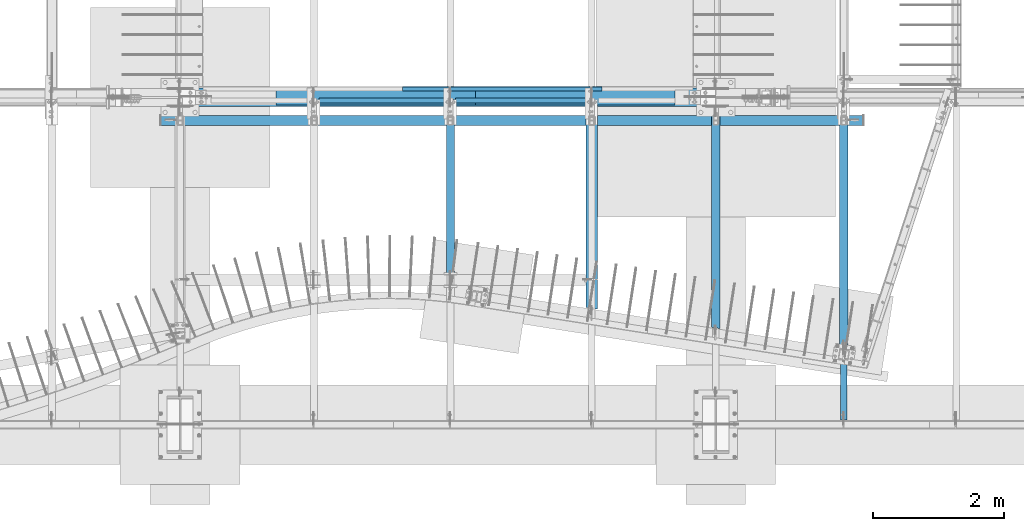
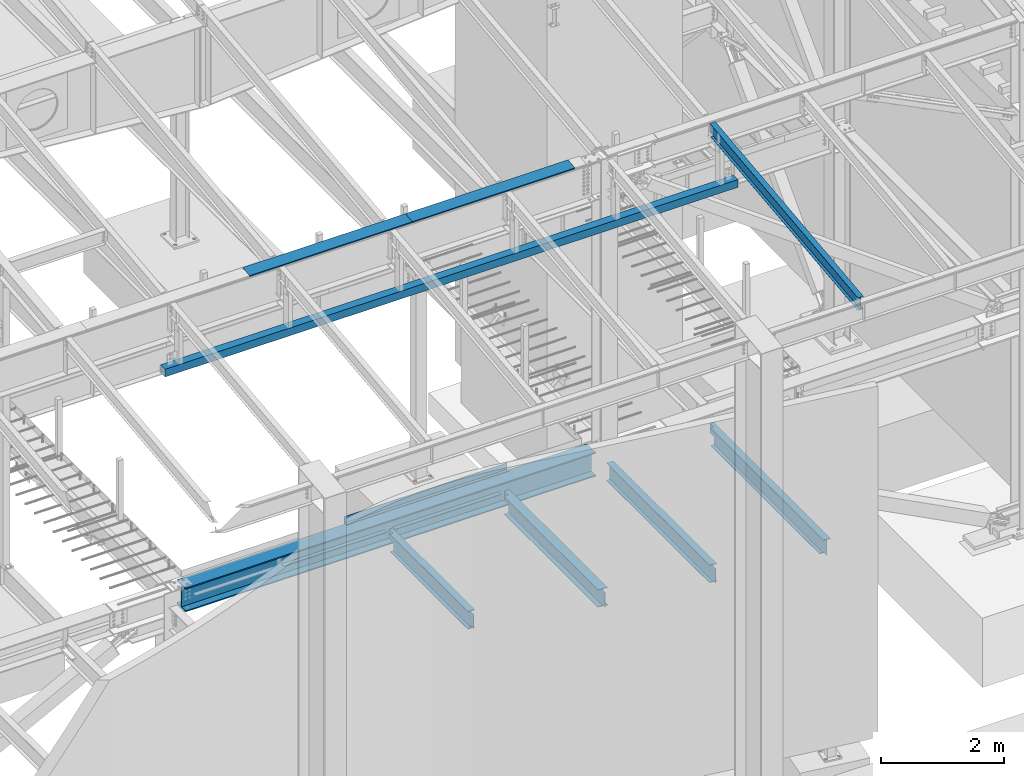
# One storey, part 713 of 1179: 12 beams, 8 elements without a shape of their own.
"""IFC2X3 building model written with IfcOpenShell, lengths in millimetres."""

from ifc_helpers import new_model, si_unit, frame, origin_with_axes, place, context, subcontext, project, spatial, faceted_brep, material, type_object, element, aggregate, save


model = new_model("IFC2X3")

# Units and contexts
model_context = context("Model", 3, precision=1e-05, world=origin_with_axes())
body_context = subcontext(model_context, "Body", "Model", "MODEL_VIEW")
ifc_project = project(units=[si_unit("LENGTHUNIT", "METRE", prefix="MILLI"), si_unit("AREAUNIT", "SQUARE_METRE"), si_unit("VOLUMEUNIT", "CUBIC_METRE"), si_unit("MASSUNIT", "GRAM", prefix="KILO"), si_unit("TIMEUNIT", "SECOND"), si_unit("PLANEANGLEUNIT", "RADIAN"), si_unit("SOLIDANGLEUNIT", "STERADIAN"), si_unit("THERMODYNAMICTEMPERATUREUNIT", "DEGREE_CELSIUS"), si_unit("LUMINOUSINTENSITYUNIT", "LUMEN")], contexts=[model_context])

# Site, building, storey
site_placement = place(None, origin_with_axes())
site = spatial("IfcSite", under=ifc_project, at=site_placement, CompositionType="ELEMENT")
building_placement = place(site_placement, origin_with_axes())
building = spatial("IfcBuilding", under=site, at=building_placement, Name="Undefined", CompositionType="ELEMENT")
storey_placement = place(building_placement, origin_with_axes())
storey = spatial("IfcBuildingStorey", under=building, at=storey_placement, Name="Undefined", CompositionType="ELEMENT", Elevation=0.0)

# Assembly, beam
assembly_1_placement = place(storey_placement, origin_with_axes())
assembly_1 = element("IfcElementAssembly", 1, at=assembly_1_placement, inside=storey, Name="BEAM", AssemblyPlace="NOTDEFINED", PredefinedType="RIGID_FRAME")
ifc_material_1 = material(Name="STEEL/A992")
beam_type_1 = type_object("IfcBeamType", Name="W10X12", PredefinedType="NOTDEFINED")
beam_1_placement = place(assembly_1_placement, frame((18415.0, 452.231593993459, 9171.78056384809), z_axis=(-3.89779463887408e-08, -0.112282221021699, 0.993676357192035), x_axis=(0.0, 0.993676357192036, 0.112282221021699)))
beam_1 = element("IfcBeam", 2, at=beam_1_placement, type_object=beam_type_1, material=ifc_material_1, Name="BEAM", ObjectType="W10X12", context=body_context, shape_type="Brep", body=[
    faceted_brep([(4858.49015079339, 2.38124999999854, -120.649999999368), (4858.49015079341, 2.38119320135957, -125.412499999364), (4858.49013956012, 50.7999999999993, -125.412499999362), (4858.49013956012, 50.7999999999993, -120.649999999367), (4983.08589598448, 2.38124999999854, -120.649999999354), (4982.54774885665, 2.38122198294514, -125.412499999351), (48.8806597554974, -2.38124999999854, -120.649999999914), (48.8806597554974, -50.7999999999993, -120.649999999914), (4858.49016309746, -50.7999999999993, -120.649999999367), (4858.49015186424, -2.38124999999854, -120.649999999367), (76.1467808989316, 2.38124999999854, 120.649999999929), (76.1467808989316, 50.7999999999993, 120.649999999929), (4914.49585701086, 50.7999999999993, 120.650000000478), (4914.49585701086, 2.38124999999854, 120.650000000478), (48.3425126276663, -50.7999999999993, -125.412499999911), (76.1467808989316, -2.38124999999854, 120.649999999929), (76.1467808989316, -50.7999999999993, 120.649999999929), (76.6849280267622, -50.7999999999993, 125.412499999924), (76.6849280267622, 50.7999999999993, 125.412499999924), (48.8806597554974, 2.38124999999854, -120.649999999914), (48.8806597554974, 50.7999999999993, -120.649999999914), (48.3425126276663, 50.7999999999993, -125.412499999911), (4858.49016309746, -50.7999999999993, -125.412499999364), (4858.49015186426, -2.38130674932472, -125.412499999364), (4983.08589598448, -2.38124999999854, -120.649999999354), (4982.54774885665, -2.3812779679356, -125.412499999351), (4916.56631885514, -2.38124999999854, 69.1498492601459), (4912.78131142652, -2.38124999999854, 72.3480766489138), (4910.50832916744, -2.38124999999854, 76.7513131080195), (4910.0934130222, -2.38124999999854, 81.6892058020039), (4914.49585701086, -2.38124999999854, 120.650000000478), (4983.1719256045, -2.38124999999854, -119.888654181221), (5003.31510185873, -2.38124999999854, 58.3746347029464), (4921.28711838346, -2.38124999999854, 67.6435320696546), (4914.49585701086, -50.7999999999993, 120.650000000478), (4915.03400413869, -50.7999999999993, 125.412500000475), (4915.03400413869, 50.7999999999993, 125.412500000475), (4910.0934130222, 2.38124999999854, 81.6892058020039), (4910.50832916744, 2.38124999999854, 76.7513131080195), (4912.78131142652, 2.38124999999854, 72.3480766489138), (4916.56631885514, 2.38124999999854, 69.1498492601459), (4921.28711838346, 2.38124999999854, 67.6435320696546), (5003.31510185873, 2.38124999999854, 58.3746347029464), (4983.17191277243, 2.38124999999854, -119.888767742599)], [[[0, 1, 2, 3]], [[4, 5, 1, 0]], [[6, 7, 8, 9]], [[10, 11, 12, 13]], [[14, 7, 6, 15, 16, 17, 18, 11, 10, 19, 20, 21]], [[7, 14, 22, 8]], [[8, 22, 23, 9]], [[24, 9, 23, 25]], [[26, 27, 28, 29, 30, 15, 6, 9, 24, 31, 32, 33]], [[16, 15, 30, 34]], [[17, 16, 34, 35]], [[18, 17, 35, 36]], [[11, 18, 36, 12]], [[35, 34, 30, 29, 37, 13, 12, 36]], [[28, 38, 37, 29]], [[27, 39, 38, 28]], [[26, 40, 39, 27]], [[33, 41, 40, 26]], [[32, 42, 41, 33]], [[43, 4, 0, 19, 10, 13, 37, 38, 39, 40, 41, 42]], [[20, 19, 0, 3]], [[21, 20, 3, 2]], [[25, 23, 22, 14, 21, 2, 1, 5]], [[43, 42, 32, 31, 24, 25, 5, 4]]]),
])
aggregate(assembly_1, [beam_1])

assembly_2_placement = place(storey_placement, origin_with_axes())
assembly_2 = element("IfcElementAssembly", 3, at=assembly_2_placement, inside=storey, Name="BEAM", AssemblyPlace="NOTDEFINED", PredefinedType="RIGID_FRAME")
ifc_material_2 = material(Name="STEEL/A36")
beam_type_2 = type_object("IfcBeamType", PredefinedType="NOTDEFINED")
beam_2_placement = place(assembly_2_placement, frame((13198.475, 5597.525, 4235.45000610352), z_axis=(1.0, 0.0, 0.0), x_axis=(0.0, 0.0, -1.0)))
beam_2 = element("IfcBeam", 4, at=beam_2_placement, type_object=beam_type_2, material=ifc_material_2, Name="BENT_PLATE", context=body_context, shape_type="Brep", body=[
    faceted_brep([(0.0, -3.17499999999927, -1524.0), (6.00266503170133e-10, -3.17499999922438, 1524.00000000052), (6.00266503170133e-10, 3.17500000077416, 1524.00000000052), (0.0, 3.17499999999927, -1524.0), (133.350006103513, 3.17500000000291, 1524.0), (133.350006103513, 3.17500000000291, -1524.0), (127.000006103513, -3.17500000000291, -1524.0), (127.000006103513, -3.17500000000291, 1524.0), (133.350006103516, -60.3250000000016, 1524.0), (133.350006103516, -60.3250000000016, -1524.0), (127.000006103515, -60.3250000000016, 1524.0), (127.000006103515, -60.3250000000016, -1524.0)], [[[0, 1, 2, 3]], [[3, 2, 4, 5]], [[1, 0, 6, 7]], [[5, 4, 8, 9]], [[4, 2, 1, 7, 10, 8]], [[7, 6, 11, 10]], [[6, 0, 3, 5, 9, 11]], [[10, 11, 9, 8]]]),
])

# Assembly, beams
assembly_3_placement = place(storey_placement, origin_with_axes())
assembly_3 = element("IfcElementAssembly", 5, at=assembly_3_placement, inside=storey, Name="BEAM", AssemblyPlace="NOTDEFINED", PredefinedType="RIGID_FRAME")
beam_type_3 = type_object("IfcBeamType", PredefinedType="NOTDEFINED")
beam_3_placement = place(assembly_3_placement, frame((14316.0749993252, 5543.55933465636, 9826.91628422077), z_axis=(-1.0, 0.0, 0.0), x_axis=(0.0, 0.0, 1.0)))
beam_3 = element("IfcBeam", 6, at=beam_3_placement, type_object=beam_type_3, material=ifc_material_2, Name="BENT_PLATE", context=body_context, shape_type="Brep", body=[
    faceted_brep([(-2.91038304567337e-11, -4.76250000000073, -1524.0), (-2.91038304567337e-11, -4.76250000000073, 1524.0), (2.91038304567337e-11, 4.76250000000073, 1524.0), (2.91038304567337e-11, 4.76250000000073, -1524.0), (46.9151566473611, 4.76249999974698, 1524.0), (46.9151566473611, 4.76249999974698, -1524.0), (36.2535598523627, -4.76250000019536, -1524.0), (36.2535598523627, -4.76250000019536, 1524.0), (21.449529282756, -220.662499999238, 1524.0), (21.449529282756, -220.662499999238, -1524.0), (12.939957335464, -211.13749999934, -1524.0), (12.939957335464, -211.13749999934, 1524.0), (1.17463059723377e-07, -220.662499999494, 1524.0), (1.17463059723377e-07, -220.662499999494, -1524.0), (1.17350282380357e-07, -211.137499999494, 1524.0), (1.17350282380357e-07, -211.137499999494, -1524.0)], [[[0, 1, 2, 3]], [[3, 2, 4, 5]], [[1, 0, 6, 7]], [[5, 4, 8, 9]], [[7, 6, 10, 11]], [[9, 8, 12, 13]], [[8, 4, 2, 1, 7, 11, 14, 12]], [[11, 10, 15, 14]], [[10, 6, 0, 3, 5, 9, 13, 15]], [[14, 15, 13, 12]]]),
])
beam_4_placement = place(assembly_3_placement, frame((11268.0749993267, 5543.55933465737, 9826.91628422066), z_axis=(-1.0, 0.0, 0.0), x_axis=(0.0, 0.0, 1.0)))
beam_4 = element("IfcBeam", 7, at=beam_4_placement, type_object=beam_type_3, material=ifc_material_2, Name="BENT_PLATE", context=body_context, shape_type="Brep", body=[
    faceted_brep([(-2.91038304567337e-11, -4.76250000000073, -1524.0), (-2.91038304567337e-11, -4.76250000000073, 1524.0), (2.91038304567337e-11, 4.76250000000073, 1524.0), (2.91038304567337e-11, 4.76250000000073, -1524.0), (46.9151566473611, 4.76249999974698, 1524.0), (46.9151566473611, 4.76249999974698, -1524.0), (36.2535598523627, -4.76250000019536, -1524.0), (36.2535598523627, -4.76250000019536, 1524.0), (21.449529282756, -220.662499999238, 1524.0), (21.449529282756, -220.662499999238, -1524.0), (12.939957335464, -211.13749999934, -1524.0), (12.939957335464, -211.13749999934, 1524.0), (1.17463059723377e-07, -220.662499999494, 1524.0), (1.17463059723377e-07, -220.662499999494, -1524.0), (1.17350282380357e-07, -211.137499999494, 1524.0), (1.17350282380357e-07, -211.137499999494, -1524.0)], [[[0, 1, 2, 3]], [[3, 2, 4, 5]], [[1, 0, 6, 7]], [[5, 4, 8, 9]], [[7, 6, 10, 11]], [[9, 8, 12, 13]], [[8, 4, 2, 1, 7, 11, 14, 12]], [[11, 10, 15, 14]], [[10, 6, 0, 3, 5, 9, 13, 15]], [[14, 15, 13, 12]]]),
])
aggregate(assembly_3, [beam_3, beam_4])

# Beam
beam_type_4 = type_object("IfcBeamType", PredefinedType="NOTDEFINED")
beam_5_placement = place(assembly_2_placement, frame((12484.1, 5390.35625, 3844.13073387436), z_axis=(0.0, 1.0, 0.0), x_axis=(1.0, 0.0, 0.0)))
beam_5 = element("IfcBeam", 8, at=beam_5_placement, type_object=beam_type_4, material=ifc_material_2, Name="PLATE", context=body_context, shape_type="Brep", body=[
    faceted_brep([(0.0, 3.96900000000005, -38.1000000000004), (0.0, 3.96900000000005, 38.1000000000004), (1984.375, 3.96900000000005, 38.1000000000004), (1984.375, 3.96900000000005, -38.1000000000004), (-3.63797880709171e-12, -3.96900000000005, 38.1000000000004), (1984.375, -3.96900000000005, 38.1000000000004), (-3.63797880709171e-12, -3.96900000000005, -38.1000000000004), (1984.375, -3.96900000000005, -38.1000000000004)], [[[0, 1, 2, 3]], [[1, 4, 5, 2]], [[4, 6, 7, 5]], [[6, 0, 3, 7]], [[5, 7, 3, 2]], [[6, 4, 1, 0]]]),
])

beam_6_placement = place(assembly_2_placement, frame((10401.3, 5390.35625, 3844.13073387436), z_axis=(0.0, 1.0, 0.0), x_axis=(1.0, 0.0, 0.0)))
beam_6 = element("IfcBeam", 9, at=beam_6_placement, type_object=beam_type_4, material=ifc_material_2, Name="PLATE", context=body_context, shape_type="Brep", body=[
    faceted_brep([(0.0, 3.96900000000005, -38.1000000000004), (0.0, 3.96900000000005, 38.1000000000004), (1930.4, 3.96900000000005, 38.1000000000004), (1930.4, 3.96900000000005, -38.1000000000004), (-3.63797880709171e-12, -3.96900000000005, 38.1000000000004), (1930.4, -3.96900000000005, 38.1000000000004), (-3.63797880709171e-12, -3.96900000000005, -38.1000000000004), (1930.4, -3.96900000000005, -38.1000000000004)], [[[0, 1, 2, 3]], [[1, 4, 5, 2]], [[4, 6, 7, 5]], [[6, 0, 3, 7]], [[5, 7, 3, 2]], [[6, 4, 1, 0]]]),
])

# Assembly, beam
assembly_4_placement = place(storey_placement, origin_with_axes())
assembly_4 = element("IfcElementAssembly", 10, at=assembly_4_placement, inside=storey, Name="BEAM", AssemblyPlace="NOTDEFINED", PredefinedType="RIGID_FRAME")
ifc_material_3 = material()
beam_type_5 = type_object("IfcBeamType", Name="HSS6X6X1/4", PredefinedType="NOTDEFINED")
beam_7_placement = place(assembly_4_placement, frame((7975.6, 5086.35, 8724.9), z_axis=(0.0, 0.0, 1.0), x_axis=(1.0, 0.0, 0.0)))
beam_7 = element("IfcBeam", 11, at=beam_7_placement, type_object=beam_type_5, material=ifc_material_3, Name="BEAM", ObjectType="HSS6X6X1/4", context=body_context, shape_type="Brep", body=[
    faceted_brep([(6.34999999999945, 69.8500000000004, -69.8500000000004), (6.34999999999945, -69.8500000000004, -69.8500000000004), (10737.85, -69.8500000000004, -69.8500000000004), (10737.85, 69.8500000000004, -69.8500000000004), (6.34999999999945, -69.8500000000004, 69.8500000000004), (10737.85, -69.8500000000004, 69.8500000000004), (6.34999999999945, 69.8500000000004, 69.8500000000004), (10737.85, 69.8500000000004, 69.8500000000004), (6.34999999999945, 76.1999999999998, -76.2000000000007), (6.34999999999945, 76.1999999999998, 76.2000000000007), (10737.85, 76.1999999999998, 76.2000000000007), (10737.85, 76.1999999999998, -76.2000000000007), (6.34999999999945, -76.1999999999998, 76.2000000000007), (10737.85, -76.1999999999998, 76.2000000000007), (6.34999999999945, -76.1999999999998, -76.2000000000007), (10737.85, -76.1999999999998, -76.2000000000007)], [[[0, 1, 2, 3]], [[1, 4, 5, 2]], [[4, 6, 7, 5]], [[6, 0, 3, 7]], [[8, 9, 10, 11]], [[9, 12, 13, 10]], [[12, 14, 15, 13]], [[14, 8, 11, 15]], [[13, 15, 11, 10], [5, 7, 3, 2]], [[14, 12, 9, 8], [6, 4, 1, 0]]]),
])
aggregate(assembly_4, [beam_7])

assembly_5_placement = place(storey_placement, origin_with_axes())
assembly_5 = element("IfcElementAssembly", 12, at=assembly_5_placement, inside=storey, Name="BEAM", AssemblyPlace="NOTDEFINED", PredefinedType="RIGID_FRAME")
beam_type_6 = type_object("IfcBeamType", Name="W14X26", PredefinedType="NOTDEFINED")
beam_8_placement = place(assembly_5_placement, frame((12407.9, 2647.95, 3671.8875), z_axis=(0.0, 0.0, 1.0), x_axis=(0.0, 1.0, 0.0)))
beam_8 = element("IfcBeam", 13, at=beam_8_placement, type_object=beam_type_6, material=ifc_material_1, Name="BEAM", ObjectType="W14X26", context=body_context, shape_type="Brep", body=[
    faceted_brep([(2620.9625003817, 28.5749995954666, 176.2125), (2620.9625003817, 28.5749995954666, 165.1), (2620.96250020706, 63.5, 165.1), (2620.96250020706, 63.5, 176.2125), (2622.89596027548, 18.8548405690453, 176.2125), (2622.89596027548, 18.8548405690453, 165.1), (2628.40198811764, 10.6144876602702, 176.2125), (2628.40198811764, 10.6144876602702, 165.1), (2636.64234108148, 5.10845990051894, 176.2125), (2636.64234108148, 5.10845990051894, 165.1), (2646.36250012724, 3.17500010394724, 176.2125), (2646.36250012724, 3.17499999999927, 165.1), (2755.10639088957, 3.17500064769047, 176.2125), (2755.10638849583, 3.17499999999927, 165.1), (95.2499884076783, 3.17499999999927, 165.1), (95.2499884076783, 63.5, 165.1), (101.665597189517, 63.5, 176.2125), (101.665597189517, -63.5, 176.2125), (2755.10638849583, -63.5, 176.2125), (2755.10638849583, -63.5, 165.1), (95.2499884076783, -63.5, 165.1), (2755.10638849583, -3.17499999999927, 165.1), (95.2499884076783, -3.17499999999927, 165.1), (95.020787505794, 3.17499999999927, 164.703000259399), (95.020787505794, -3.17499999999927, 164.703000259399), (117.474996948922, 3.17499999999927, 164.703000259399), (117.474996948922, -3.17499999999927, 164.703000259399), (133.804034531066, 3.17499999999927, 158.045004848507), (133.804034531066, -3.17499999999927, 158.045004848507), (137.888773595438, 3.17499999999927, 154.857742002601), (137.888773595438, -3.17499999999927, 154.857742002601), (139.700870417409, 3.17499999999927, 150.003873155928), (139.700870417409, -3.17499999999927, 150.003873155928), (138.704164947125, 3.17499999999927, 144.919552564306), (138.704164947125, -3.17499999999927, 144.919552564306), (135.193560662237, 3.17499999999927, 141.10912014425), (135.193560662237, -3.17499999999927, 141.10912014425), (130.207769040842, 3.17499999999927, 139.7), (130.207769040842, -3.17499999999927, 139.7), (15.8750000000027, 3.17499999999927, 139.7), (15.8750000000027, -3.17499999999927, 139.7), (15.8750000000027, 3.17499999999927, 138.112500000001), (15.8750000000027, 3.17499999999927, -92.4874999999997), (15.8750000000027, 3.17499999999927, -139.7), (15.8750000000027, -3.17499999999927, -139.7), (137.081772947067, 3.17499999999927, -139.7), (137.081772947067, -3.17499999999927, -139.7), (142.067564568461, 3.17499999999927, -141.10912014425), (142.067564568461, -3.17499999999927, -141.10912014425), (145.578168853349, 3.17499999999927, -144.919552564306), (145.578168853349, -3.17499999999927, -144.919552564306), (146.574874323633, 3.17499999999927, -150.003873155929), (146.574874323633, -3.17499999999927, -150.003873155929), (144.762777501662, 3.17499999999927, -154.857742002601), (144.762777501662, -3.17499999999927, -154.857742002601), (140.678038437291, 3.17499999999927, -158.045004848507), (140.678038437291, -3.17499999999927, -158.045004848507), (124.349000855147, 3.17499999999927, -164.703000259399), (124.349000855147, -3.17499999999927, -164.703000259399), (101.894810700874, 3.17499999999927, -164.703000259399), (101.894810700874, -3.17499999999927, -164.703000259399), (101.665622677133, -3.17499999999927, -165.1), (2620.96249811497, -3.17499999999927, -165.1), (2620.96249811497, -3.17499999999927, -36.5124996185305), (2622.89595796015, -3.17499999999927, -26.7923405824395), (2628.4019857611, -3.17499999999927, -18.5519876461321), (2636.64233869741, -3.17499999999927, -13.0459598451757), (2646.3624977335, -3.17499999999927, -11.1125000000002), (2755.10638849583, -3.17499999999927, -11.1125000000002), (95.2503743700081, 63.5, -176.2125), (101.665622677133, 63.5, -165.1), (2620.96249811497, 63.5, -165.1), (2620.96249811497, 63.5, -176.2125), (2620.96249811497, -63.5, -176.2125), (95.2503743700081, -63.5, -176.2125), (2620.96249811497, 28.5749995954666, -176.2125), (101.665622677133, -63.5, -165.1), (2620.96249811497, -63.5, -165.1), (101.665622677133, 3.17499999999927, -165.1), (2620.96249811497, 3.17499999999927, -165.1), (2620.96249811497, 28.5749995954666, -165.1), (2620.96249811497, 3.17499999999927, -36.5124996185305), (2622.89595796015, 3.17499999999927, -26.7923405824395), (2628.4019857611, 3.17499999999927, -18.5519876461321), (2636.64233869741, 3.17499999999927, -13.0459598451757), (2646.3624977335, 3.17499999999927, -11.1125000000002), (2755.10638849583, 3.17499999999927, -11.1125000000002)], [[[0, 1, 2, 3]], [[4, 5, 1, 0]], [[6, 7, 5, 4]], [[8, 9, 7, 6]], [[10, 11, 9, 8]], [[12, 13, 11, 10]], [[14, 15, 2, 1, 5, 7, 9, 11]], [[15, 16, 3, 2]], [[8, 6, 4, 0, 3, 16, 17, 18, 12, 10]], [[19, 18, 17, 20]], [[21, 19, 20, 22]], [[17, 16, 15, 14, 23, 24, 22, 20]], [[25, 26, 24, 23]], [[26, 25, 27, 28]], [[28, 27, 29, 30]], [[30, 29, 31, 32]], [[32, 31, 33, 34]], [[34, 33, 35, 36]], [[36, 35, 37, 38]], [[38, 37, 39, 40]], [[41, 42, 43, 44, 40, 39]], [[44, 43, 45, 46]], [[46, 45, 47, 48]], [[48, 47, 49, 50]], [[50, 49, 51, 52]], [[52, 51, 53, 54]], [[54, 53, 55, 56]], [[56, 55, 57, 58]], [[58, 57, 59, 60]], [[21, 22, 24, 26, 28, 30, 32, 34, 36, 38, 40, 44, 46, 48, 50, 52, 54, 56, 58, 60, 61, 62, 63, 64, 65, 66, 67, 68]], [[69, 70, 71, 72]], [[73, 74, 69, 72, 75]], [[76, 74, 73, 77]], [[61, 76, 77, 62]], [[60, 59, 78, 70, 69, 74, 76, 61]], [[71, 70, 78, 79, 80]], [[62, 77, 73, 75, 72, 71, 80, 79, 81, 63]], [[63, 81, 82, 64]], [[64, 82, 83, 65]], [[65, 83, 84, 66]], [[66, 84, 85, 67]], [[68, 67, 85, 86]], [[84, 83, 82, 81, 79, 78, 59, 57, 55, 53, 51, 49, 47, 45, 43, 42, 41, 39, 37, 35, 33, 31, 29, 27, 25, 23, 14, 11, 13, 86, 85]], [[18, 19, 21, 68, 86, 13, 12]]]),
])
aggregate(assembly_5, [beam_8])

assembly_6_placement = place(storey_placement, origin_with_axes())
assembly_6 = element("IfcElementAssembly", 14, at=assembly_6_placement, inside=storey, Name="BEAM", AssemblyPlace="NOTDEFINED", PredefinedType="RIGID_FRAME")
beam_9_placement = place(assembly_6_placement, frame((18415.0, 1508.125, 3671.8875), z_axis=(0.0, 0.0, 1.0), x_axis=(0.0, 1.0, 0.0)))
beam_9 = element("IfcBeam", 15, at=beam_9_placement, type_object=beam_type_6, material=ifc_material_1, Name="BEAM", ObjectType="W14X26", context=body_context, shape_type="Brep", body=[
    faceted_brep([(99.9511229716845, -3.17499999999927, -147.6375), (100.956076547899, 3.17499999999927, -147.6375), (215.816564194319, 3.17499999999927, -147.6375), (215.816564194319, -3.17499999999927, -147.6375), (220.676643712365, 3.17499999999927, -148.604229922588), (220.676643712365, -3.17499999999927, -148.604229922588), (224.796820180519, 3.17499999999927, -151.357243823066), (224.796820180519, -3.17499999999927, -151.357243823066), (227.549834080997, 3.17499999999927, -155.47742029122), (227.549834080997, -3.17499999999927, -155.47742029122), (228.516564003585, -3.17499999999927, -160.337499809265), (228.516564003585, 3.17499999999927, -160.337499809265), (228.516564003584, 3.17499999999927, -165.1), (228.516564003585, 63.5, -165.1), (228.516564003585, 63.5, -176.2125), (228.516564003584, -63.5, -176.2125), (228.516564003584, -63.5, -165.1), (228.516564003584, -3.17499999999927, -165.1), (3759.9938905532, 28.5750178928865, -165.1), (3759.9938905532, 28.5750178928865, -176.2125), (3759.9938905532, 63.5, -176.2125), (3759.9938905532, 63.5, -165.1), (100.956076547899, 3.17499999999927, 165.1), (110.503135521938, 63.5, 165.1), (3759.9938905532, 63.5, 165.1), (3759.9938905532, 28.5750178928865, 165.1), (3761.92735039838, 18.8548588567937, 165.1), (3767.43337819933, 10.6145059204864, 165.1), (3775.67373113564, 5.10847811953136, 165.1), (3785.39389017173, 3.17499999999927, 165.1), (110.503135521938, 63.5, 176.2125), (3759.9938905532, 63.5, 176.2125), (3759.9938905532, 28.5750178928865, 176.2125), (3761.92735039838, 18.8548588567937, 176.2125), (3767.43337819933, 10.6145059204864, 176.2125), (3775.67373113564, 5.10847811953136, 176.2125), (3785.39389017173, 3.17501827435626, 176.2125), (3894.93138750144, 3.17501827435626, 176.2125), (3894.93138750144, 3.17499999999927, 165.1), (90.4040639976461, -63.5, 176.2125), (3894.93138750144, -63.5, 176.2125), (90.4040639976461, -63.5, 165.1), (3894.93138750144, -63.5, 165.1), (99.9511229716845, -3.17499999999927, 165.1), (3894.93138750144, -3.17499999999927, 165.1), (3894.9313905532, -3.17499999999927, -11.1125000000002), (3894.93138750144, 3.17499999999927, -11.1125000000002), (3785.39389017173, -3.17499999999927, -11.1125000000002), (3785.39389017173, 3.17499999999927, -11.1125000000002), (3775.67373113564, -3.17499999999927, -13.0459598451757), (3775.67373113564, 3.17499999999927, -13.0459598451757), (3767.43337819933, -3.17499999999927, -18.5519876461321), (3767.43337819933, 3.17499999999927, -18.5519876461321), (3761.92735039838, -3.17499999999927, -26.7923405824395), (3761.92735039838, 3.17499999999927, -26.7923405824395), (3759.9938905532, -3.17499999999927, -36.5124996185305), (3759.9938905532, 3.17499999999927, -36.5124996185305), (3759.9938905532, -3.17499999999927, -165.1), (3759.9938905532, -63.5, -165.1), (3759.9938905532, -63.5, -176.2125), (3759.9938905532, 3.17499999999927, -165.1)], [[[0, 1, 2, 3]], [[3, 2, 4, 5]], [[5, 4, 6, 7]], [[7, 6, 8, 9]], [[10, 11, 12, 13, 14, 15, 16, 17]], [[9, 8, 11, 10]], [[18, 19, 20, 21]], [[22, 23, 24, 25, 26, 27, 28, 29]], [[23, 30, 31, 24]], [[32, 25, 24, 31]], [[33, 26, 25, 32]], [[34, 27, 26, 33]], [[35, 28, 27, 34]], [[36, 29, 28, 35]], [[37, 38, 29, 36]], [[35, 34, 33, 32, 31, 30, 39, 40, 37, 36]], [[39, 41, 42, 40]], [[41, 43, 44, 42]], [[38, 37, 40, 42, 44, 45, 46]], [[45, 47, 48, 46]], [[49, 50, 48, 47]], [[51, 52, 50, 49]], [[53, 54, 52, 51]], [[55, 56, 54, 53]], [[57, 58, 59, 19, 18, 60, 56, 55]], [[58, 57, 17, 16]], [[59, 58, 16, 15]], [[20, 19, 59, 15, 14]], [[21, 20, 14, 13]], [[60, 18, 21, 13, 12]], [[6, 4, 2, 1, 22, 29, 38, 46, 48, 50, 52, 54, 56, 60, 12, 11, 8]], [[43, 41, 39, 30, 23, 22, 1, 0]], [[57, 55, 53, 51, 49, 47, 45, 44, 43, 0, 3, 5, 7, 9, 10, 17]]]),
])
aggregate(assembly_6, [beam_9])

assembly_7_placement = place(storey_placement, origin_with_axes())
assembly_7 = element("IfcElementAssembly", 16, at=assembly_7_placement, inside=storey, Name="BEAM", AssemblyPlace="NOTDEFINED", PredefinedType="RIGID_FRAME")
beam_10_placement = place(assembly_7_placement, frame((16459.2, 1817.65070147409, 3671.8875), z_axis=(0.0, 0.0, 1.0), x_axis=(0.0, 1.0, 0.0)))
beam_10 = element("IfcBeam", 17, at=beam_10_placement, type_object=beam_type_6, material=ifc_material_1, Name="BEAM", ObjectType="W14X26", context=body_context, shape_type="Brep", body=[
    faceted_brep([(18.1823609679932, 3.17499999999927, 144.4625), (18.1823609679545, -3.17499999999927, 144.4625), (86.311529928025, -3.17500000003929, 144.4625), (87.3165392880442, 3.17497967358577, 144.4625), (91.2321037420568, -3.17500000003929, 145.429229922588), (92.2371129854218, 3.17497893652398, 145.429229922588), (95.4035647980149, -3.17500000004293, 148.182243823066), (96.4085737149669, 3.17497687413561, 148.182243823066), (98.1908459645183, -3.17500000004657, 152.302420291219), (99.1958543949918, 3.17497380040732, 152.302420291219), (99.1696089507336, -3.17500000004657, 157.162499809265), (100.174616808725, 3.17497018327413, 157.162499809265), (109.722241009956, 63.4999999999491, 176.2125), (109.722241009956, 63.4999999999491, 165.1), (100.174621527821, 3.17499999995562, 165.1), (99.1696089507545, -3.17500000004657, 165.1), (89.6219894686189, -63.50000000004, 165.1), (89.6219894686189, -63.50000000004, 176.2125), (3448.08679852274, 3.17499999846405, -165.1), (3448.08679846239, 63.4999999984648, -165.1), (109.722241010412, 63.4999999999491, -165.1), (100.174700169435, 3.17549688065628, -165.1), (3448.08679846239, 63.4999999984648, -176.2125), (3448.08679858944, -63.5000000015352, -176.2125), (89.6219894690746, -63.50000000004, -176.2125), (109.722241010412, 63.4999999999491, -176.2125), (3448.08679858944, -63.5000000015352, -165.1), (89.6219894690746, -63.50000000004, -165.1), (3448.08679852909, -3.1750000015345, -165.1), (99.1696089512104, -3.17500000004657, -165.1), (87.3165733348703, 3.17519478944814, -147.6375), (86.3115299285289, -3.17500000003929, -147.6375), (18.1823609679545, -3.17499999999927, -147.6375), (18.1823609679932, 3.17499999999927, -147.6375), (92.2371472647349, 3.17519552131489, -148.604229922588), (91.2321037425606, -3.17500000003929, -148.604229922588), (96.4086086505567, 3.1751976054984, -151.357243823066), (95.4035647985186, -3.17500000004293, -151.357243823066), (99.1958903107363, 3.1752007247087, -155.47742029122), (98.1908459650222, -3.17500000004657, -155.47742029122), (100.174653879282, 3.17520440406588, -160.337499809265), (99.1696089512375, -3.17500000004657, -160.337499809265), (3448.08679852274, 3.17499999846405, 165.1), (3448.08679846239, 63.4999999984648, 165.1), (3448.08679846239, 63.4999999984648, 176.2125), (3448.08679858944, -63.5000000015352, 176.2125), (3448.08679858944, -63.5000000015352, 165.1), (3448.08679852909, -3.1750000015345, 165.1)], [[[0, 1, 2, 3]], [[3, 2, 4, 5]], [[5, 4, 6, 7]], [[7, 6, 8, 9]], [[9, 8, 10, 11]], [[12, 13, 14, 11, 10, 15, 16, 17]], [[18, 19, 20, 21]], [[22, 23, 24, 25]], [[23, 26, 27, 24]], [[26, 28, 29, 27]], [[30, 31, 32, 33]], [[34, 35, 31, 30]], [[36, 37, 35, 34]], [[38, 39, 37, 36]], [[40, 41, 39, 38]], [[20, 25, 24, 27, 29, 41, 40, 21]], [[19, 22, 25, 20]], [[18, 42, 43, 44, 45, 46, 47, 28, 26, 23, 22, 19]], [[45, 44, 12, 17]], [[46, 45, 17, 16]], [[47, 46, 16, 15]], [[8, 6, 4, 2, 1, 32, 31, 35, 37, 39, 41, 29, 28, 47, 15, 10]], [[33, 32, 1, 0]], [[42, 18, 21, 40, 38, 36, 34, 30, 33, 0, 3, 5, 7, 9, 11, 14]], [[43, 42, 14, 13]], [[44, 43, 13, 12]]]),
])
aggregate(assembly_7, [beam_10])

assembly_8_placement = place(storey_placement, origin_with_axes())
assembly_8 = element("IfcElementAssembly", 18, at=assembly_8_placement, inside=storey, Name="BEAM", AssemblyPlace="NOTDEFINED", PredefinedType="RIGID_FRAME")
beam_type_7 = type_object("IfcBeamType", Name="W14X30", PredefinedType="NOTDEFINED")
beam_11_placement = place(assembly_8_placement, frame((14566.9, 2117.12686718603, 3671.8875), z_axis=(0.0, 0.0, 1.0), x_axis=(0.0, 1.0, 0.0)))
beam_11 = element("IfcBeam", 19, at=beam_11_placement, type_object=beam_type_7, material=ifc_material_1, Name="BEAM", ObjectType="W14X30", context=body_context, shape_type="Brep", body=[
    faceted_brep([(18.1823609679932, 3.17499999999927, 144.4625), (18.1823609679545, -3.17499999999927, 144.4625), (86.3291141330192, -3.17499999999927, 144.4625), (87.3341173059212, 3.17494054025155, 144.4625), (91.2496879478304, -3.17499999999927, 145.429229922588), (92.2546910081446, 3.174939828883, 145.429229922588), (95.4211490044495, -3.17499999999927, 148.182243823066), (96.4261517500281, 3.17493784028193, 148.182243823066), (98.2084301713944, -3.17499999999927, 152.302420291219), (99.2134324480062, 3.17493487719184, 152.302420291219), (99.1871931577648, -3.17499999999927, 157.162499809265), (100.192194882573, 3.17493139071848, 157.162499809265), (113.257369327871, 85.7250000000004, 176.2125), (113.257369327871, 85.7250000000004, 166.6875), (100.192205741386, 3.17499999999927, 166.6875), (99.1871931578103, -3.17499999999927, 166.6875), (86.1220295713251, -85.7250000000004, 166.6875), (86.1220295713251, -85.7250000000004, 176.2125), (3151.78563092894, 85.7250000000004, -166.6875), (3151.78563092894, 85.7250000000004, -176.2125), (113.25736932777, 85.7250000000004, -176.2125), (113.25736932777, 85.7250000000004, -166.6875), (3151.78563092894, 28.5749996141403, -176.2125), (3151.78563092894, -85.7250000000004, -176.2125), (86.1220295712246, -85.7250000000004, -176.2125), (3151.78563092894, -85.7250000000004, -166.6875), (86.1220295712246, -85.7250000000004, -166.6875), (3151.78563092894, -3.17499999999927, -166.6875), (99.1871931577093, -3.17499999999927, -166.6875), (87.3341503355737, 3.1751492324529, -147.6375), (86.3291141330196, -3.17499999999927, -147.6375), (18.1823609679545, -3.17499999999927, -147.6375), (18.1823609679932, 3.17499999999927, -147.6375), (92.2547242625283, 3.17514994100929, -148.604229922588), (91.2496879478313, -3.17499999999927, -148.604229922588), (96.4261856385042, 3.17515195881242, -151.357243823066), (95.4211490044499, -3.17499999999927, -151.357243823066), (99.2134672834004, 3.17515497866589, -155.47742029122), (98.2084301713953, -3.17499999999927, -155.47742029122), (100.192230833553, 3.17515854082558, -160.337499809265), (99.1871931577657, -3.17499999999927, -160.337499809265), (100.192284328271, 3.17549653841706, -166.6875), (3151.78563092894, 3.17499999999927, -166.6875), (3151.78563092894, 28.5749996141403, -166.6875), (3151.78563092894, 3.17499999999927, -36.5124996185305), (3151.78563092894, -3.17499999999927, -36.5124996185305), (3153.71909077412, 3.17499999999927, -26.7923405824395), (3153.71909077412, -3.17499999999927, -26.7923405824395), (3159.22511857507, 3.17499999999927, -18.5519876461321), (3159.22511857507, -3.17499999999927, -18.5519876461321), (3167.46547151138, 3.17499999999927, -13.0459598451757), (3167.46547151138, -3.17499999999927, -13.0459598451757), (3177.18563054747, 3.17499999999927, -11.1125000000002), (3177.18563054747, -3.17499999999927, -11.1125000000002), (3285.9295213098, -3.17499999999927, -11.1125000000002), (3285.92913281397, 3.17499999999927, -11.1125000000002), (3285.92913281397, -85.7250000000004, 176.2125), (3285.92913281397, -85.7250000000004, 166.6875), (3285.92913281397, -3.17499999999927, 166.6875), (3285.92913281397, 3.17499999999927, 166.6875), (3285.92952370354, 3.17499758091071, 176.2125), (3177.18563294121, 3.17499999999927, 166.6875), (3177.18563294121, 3.17499953839251, 176.2125), (3167.46547393992, 5.10845955853802, 166.6875), (3167.46547393992, 5.10845955853802, 176.2125), (3159.22512110272, 10.614487507828, 166.6875), (3159.22512110272, 10.614487507828, 176.2125), (3153.71909345009, 18.8548405432466, 166.6875), (3153.71909345009, 18.8548405432466, 176.2125), (3151.78563377988, 28.5749996141403, 166.6875), (3151.78563377988, 28.5749996141403, 176.2125), (3151.78563480857, 85.7250000000004, 166.6875), (3151.78563480857, 85.7250000000004, 176.2125)], [[[0, 1, 2, 3]], [[3, 2, 4, 5]], [[5, 4, 6, 7]], [[7, 6, 8, 9]], [[9, 8, 10, 11]], [[12, 13, 14, 11, 10, 15, 16, 17]], [[18, 19, 20, 21]], [[19, 22, 23, 24, 20]], [[23, 25, 26, 24]], [[25, 27, 28, 26]], [[29, 30, 31, 32]], [[33, 34, 30, 29]], [[35, 36, 34, 33]], [[37, 38, 36, 35]], [[39, 40, 38, 37]], [[21, 20, 24, 26, 28, 40, 39, 41]], [[42, 43, 18, 21, 41]], [[27, 25, 23, 22, 19, 18, 43, 42, 44, 45]], [[45, 44, 46, 47]], [[47, 46, 48, 49]], [[49, 48, 50, 51]], [[51, 50, 52, 53]], [[54, 53, 52, 55]], [[56, 57, 58, 54, 55, 59, 60]], [[60, 59, 61, 62]], [[62, 61, 63, 64]], [[64, 63, 65, 66]], [[66, 65, 67, 68]], [[68, 67, 69, 70]], [[70, 69, 71, 72]], [[56, 60, 62, 64, 66, 68, 70, 72, 12, 17]], [[57, 56, 17, 16]], [[58, 57, 16, 15]], [[8, 6, 4, 2, 1, 31, 30, 34, 36, 38, 40, 28, 27, 45, 47, 49, 51, 53, 54, 58, 15, 10]], [[32, 31, 1, 0]], [[61, 59, 55, 52, 50, 48, 46, 44, 42, 41, 39, 37, 35, 33, 29, 32, 0, 3, 5, 7, 9, 11, 14]], [[71, 69, 67, 65, 63, 61, 14, 13]], [[72, 71, 13, 12]]]),
])
aggregate(assembly_8, [beam_11])

# Beam
beam_type_8 = type_object("IfcBeamType", Name="W18X97", PredefinedType="NOTDEFINED")
beam_12_placement = place(assembly_2_placement, frame((8280.4, 5435.6, 3865.5625), z_axis=(0.0, 0.0, 1.0), x_axis=(1.0, 0.0, 0.0)))
beam_12 = element("IfcBeam", 20, at=beam_12_placement, type_object=beam_type_8, material=ifc_material_1, Name="BEAM", ObjectType="W18X97", context=body_context, shape_type="Brep", body=[
    faceted_brep([(246.0625, -141.2875, -236.5375), (246.0625, 141.2875, -236.5375), (7931.15, 141.2875, -236.5375), (7931.15, -141.2875, -236.5375), (246.0625, -141.2875, -214.3125), (246.0625, -7.14375000000018, -214.3125), (246.0625, -7.14375000000018, 214.3125), (246.0625, -141.2875, 214.3125), (246.0625, -141.2875, 236.5375), (246.0625, 141.2875, 236.5375), (246.0625, 141.2875, 214.3125), (246.0625, 7.14375000000018, 214.3125), (246.0625, 7.14375000000018, 186.4775001777), (246.0625, 7.14375000000018, -119.802499822304), (246.0625, 7.14375000000018, -214.3125), (246.0625, 141.2875, -214.3125), (7931.15, -141.2875, -214.3125), (7931.15, -7.14375000000018, -214.3125), (7931.15, -7.14375000000018, 214.3125), (7931.15, -141.2875, 214.3125), (7931.15, -141.2875, 236.5375), (7931.15, 141.2875, 236.5375), (7931.15, 141.2875, 214.3125), (7931.15, 7.14375000000018, 214.3125), (7931.15, 7.14375000000018, 186.477500179332), (7931.15, 7.14375000000018, -119.802499820772), (7931.15, 7.14375000000018, -214.3125), (7931.15, 141.2875, -214.3125)], [[[0, 1, 2, 3]], [[0, 4, 5, 6, 7, 8, 9, 10, 11, 12, 13, 14, 15, 1]], [[5, 4, 16, 17]], [[6, 5, 17, 18]], [[7, 6, 18, 19]], [[8, 7, 19, 20]], [[9, 8, 20, 21]], [[10, 9, 21, 22]], [[11, 10, 22, 23]], [[14, 13, 12, 11, 23, 24, 25, 26]], [[15, 14, 26, 27]], [[1, 15, 27, 2]], [[26, 25, 24, 23, 22, 21, 20, 19, 18, 17, 16, 3, 2, 27]], [[4, 0, 3, 16]]]),
])

aggregate(assembly_2, [beam_2, beam_5, beam_6, beam_12])

save(model, "model.ifc")
